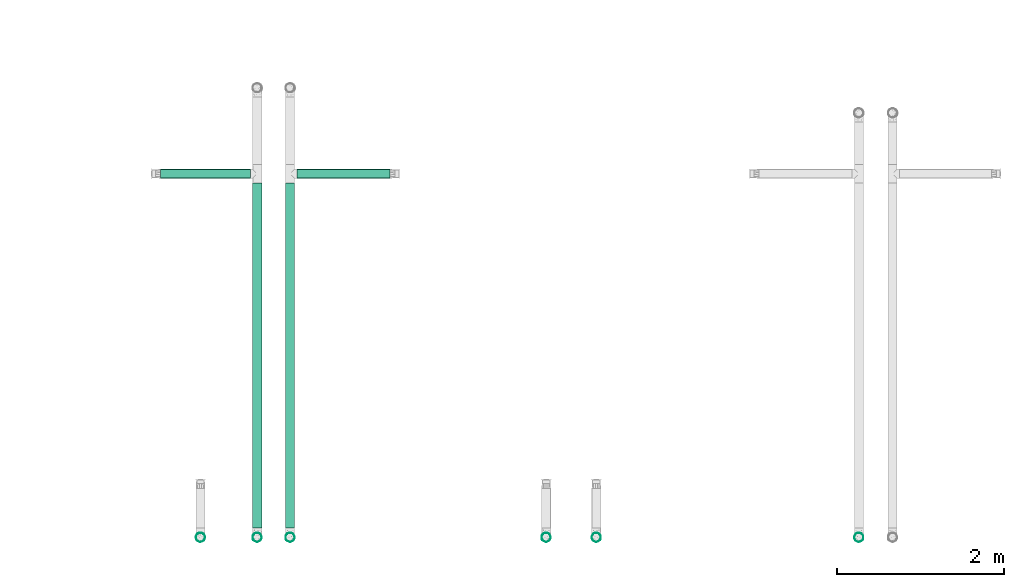
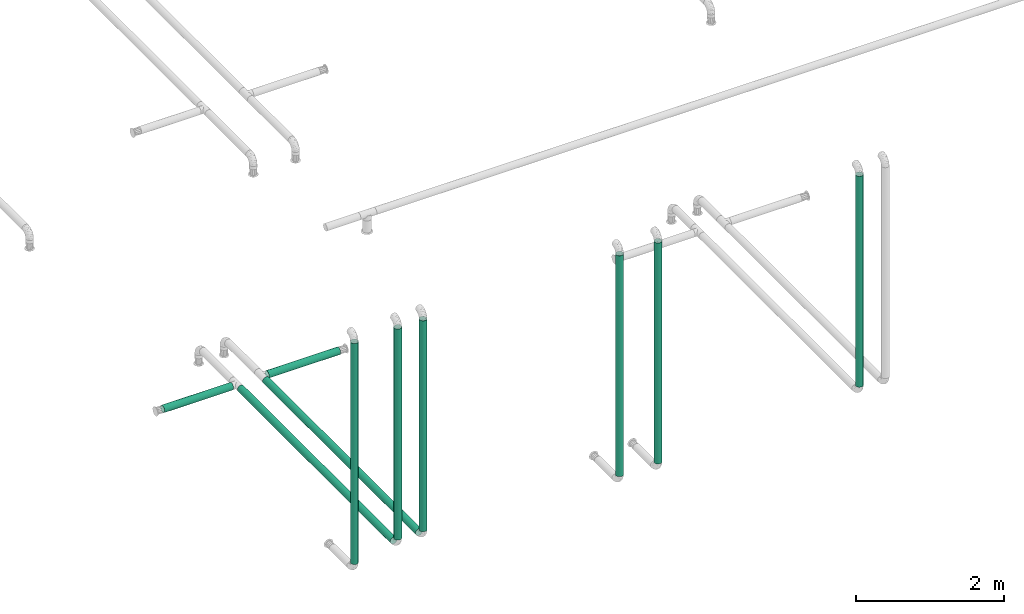
# One storey, part 1 of 115: 10 flow segments.
"""IFC2X3 building model written with IfcOpenShell, lengths in millimetres."""

from ifc_helpers import new_model, entity, si_unit, converted_unit, derived_unit, direction, frame, origin_with_axes, origin_2d_with_axis, place, context, subcontext, project, spatial, hollow_circle, extrude, source, transform, mapped, material, layer, layer_set, layer_usage, type_object, element, save


model = new_model("IFC2X3")

# Units and contexts
model_context = context("Model", 3, precision=1e-05, world=origin_with_axes(), true_north=direction((0.0, 1.0)))
body_context = subcontext(model_context, "Body", "Model", "MODEL_VIEW")
ifc_project = project(units=[si_unit("AREAUNIT", "SQUARE_METRE"), si_unit("VOLUMEUNIT", "CUBIC_METRE", prefix="DECI"), si_unit("TIMEUNIT", "SECOND"), si_unit("THERMODYNAMICTEMPERATUREUNIT", "DEGREE_CELSIUS"), si_unit("PRESSUREUNIT", "PASCAL"), si_unit("MASSUNIT", "GRAM", prefix="KILO"), si_unit("LENGTHUNIT", "METRE", prefix="MILLI"), si_unit("POWERUNIT", "WATT"), si_unit("ELECTRICCURRENTUNIT", "AMPERE"), si_unit("ELECTRICVOLTAGEUNIT", "VOLT"), derived_unit("VOLUMETRICFLOWRATEUNIT", [(si_unit("VOLUMEUNIT", "CUBIC_METRE", prefix="DECI"), 1), (si_unit("TIMEUNIT", "SECOND"), -1)]), derived_unit("LINEARVELOCITYUNIT", [(si_unit("LENGTHUNIT", "METRE"), 1), (si_unit("TIMEUNIT", "SECOND"), -1)]), derived_unit("MASSDENSITYUNIT", [(si_unit("MASSUNIT", "GRAM", prefix="KILO"), 1), (si_unit("VOLUMEUNIT", "CUBIC_METRE"), -1)]), converted_unit("PLANEANGLEUNIT", "DEGREE", entity("IfcRatioMeasure", 0.01745), si_unit("PLANEANGLEUNIT", "RADIAN"), dimensions=[0, 0, 0, 0, 0, 0, 0])], contexts=[model_context])

# Site, building, storey
site_placement = place(None, origin_with_axes())
site = spatial("IfcSite", under=ifc_project, at=site_placement, CompositionType="ELEMENT")
building_placement = place(site_placement, origin_with_axes())
building = spatial("IfcBuilding", under=site, at=building_placement, Name="mc-building", CompositionType="ELEMENT")
storey_placement = place(building_placement, frame((0.0, 0.0, 2950.0), z_axis=(0.0, 0.0, 1.0), x_axis=(1.0, 0.0, 0.0)))
storey = spatial("IfcBuildingStorey", under=building, at=storey_placement, Name="2. Korrus", CompositionType="ELEMENT", Elevation=2950.0)

# Flow segments
ifc_material = material(Name="FZ1")
ifc_layer = layer(ifc_material, 0.0)
ifc_layer_set = layer_set([ifc_layer], Name="FZ1")
ifc_layer_usage = layer_usage(ifc_layer_set, "AXIS1", "POSITIVE", 0.0)
duct_segment_type_1 = type_object("IfcDuctSegmentType", PredefinedType="RIGIDSEGMENT")
shared_shape_1 = source(origin_with_axes(), body_context, "Body", "SweptSolid", [
    extrude(hollow_circle(Radius=55.0, WallThickness=2.0, at=origin_2d_with_axis()), frame((0.0, 0.0, 0.0), z_axis=(1.0, 0.0, 0.0), x_axis=(0.0, 1.0, 0.0)), (0.0, 0.0, 1.0), 3480.0),
])
for number, where, z_axis, x_axis in (
    (1, (15796.4103, -687.64676, 2575.0), (1.0, 0.0, 0.0), (0.0, 0.0, 1.0)),
    (2, (8987.56202, -687.64676, 2575.0), (1.0, 0.0, 0.0), (0.0, 0.0, 1.0)),
    (3, (8592.78509, -687.64676, 2575.0), (1.0, 0.0, 0.0), (0.0, 0.0, 1.0)),
):
    element("IfcFlowSegment", number, at=place(storey_placement, frame(where, z_axis=z_axis, x_axis=x_axis)), inside=storey, type_object=duct_segment_type_1, material=ifc_layer_usage, context=body_context, shape_type="MappedRepresentation", body=[
        mapped(shared_shape_1, transform((0.0, 0.0, 0.0), scale=1.0)),
    ])
duct_segment_type_2 = type_object("IfcDuctSegmentType", Name="Safe", PredefinedType="RIGIDSEGMENT")
shared_shape_2 = source(origin_with_axes(), body_context, "Body", "SweptSolid", [
    extrude(hollow_circle(Radius=55.0, WallThickness=2.0, at=origin_2d_with_axis()), frame((0.0, 0.0, 0.0), z_axis=(1.0, 0.0, 0.0), x_axis=(0.0, 1.0, 0.0)), (0.0, 0.0, 1.0), 3645.0),
])
for number, where, z_axis, x_axis, name in (
    (4, (12653.05388, -687.64676, 2410.0), (1.0, 0.0, 0.0), (0.0, 0.0, 1.0), "Safe"),
    (5, (12053.05418, -687.64676, 2410.0), (1.0, 0.0, 0.0), (0.0, 0.0, 1.0), "Safe"),
    (6, (7914.47808, -687.64676, 2410.0), (1.0, 0.0, 0.0), (0.0, 0.0, 1.0), "Safe"),
):
    element("IfcFlowSegment", number, at=place(storey_placement, frame(where, z_axis=z_axis, x_axis=x_axis)), inside=storey, type_object=duct_segment_type_2, material=ifc_layer_usage, Name=name, context=body_context, shape_type="MappedRepresentation", body=[
        mapped(shared_shape_2, transform((0.0, 0.0, 0.0), scale=1.0)),
    ])
shared_shape_3 = source(origin_with_axes(), body_context, "Body", "SweptSolid", [
    extrude(hollow_circle(Radius=55.0, WallThickness=2.0, at=origin_2d_with_axis()), frame((0.0, 0.0, 0.0), z_axis=(1.0, 0.0, 0.0), x_axis=(0.0, 1.0, 0.0)), (0.0, 0.0, 1.0), 4133.9),
])
for number, where, z_axis, x_axis in (
    (7, (8987.56202, -577.64676, 2465.0), (0.0, 0.0, 1.0), (0.0, 1.0, 0.0)),
    (8, (8592.78509, -577.64676, 2465.0), (0.0, 0.0, 1.0), (0.0, 1.0, 0.0)),
):
    element("IfcFlowSegment", number, at=place(storey_placement, frame(where, z_axis=z_axis, x_axis=x_axis)), inside=storey, type_object=duct_segment_type_1, material=ifc_layer_usage, context=body_context, shape_type="MappedRepresentation", body=[
        mapped(shared_shape_3, transform((0.0, 0.0, 0.0), scale=1.0)),
    ])
shared_shape_4 = source(origin_with_axes(), body_context, "Body", "SweptSolid", [
    extrude(hollow_circle(Radius=55.0, WallThickness=2.0, at=origin_2d_with_axis()), frame((0.0, 0.0, 0.0), z_axis=(1.0, 0.0, 0.0), x_axis=(0.0, 1.0, 0.0)), (0.0, 0.0, 1.0), 1117.3),
])
flow_segment_1_placement = place(storey_placement, frame((9067.56202, 3666.26111, 2465.0), z_axis=(0.0, 0.0, 1.0), x_axis=(1.0, 0.0, 0.0)))
element("IfcFlowSegment", 9, at=flow_segment_1_placement, inside=storey, type_object=duct_segment_type_1, material=ifc_layer_usage, context=body_context, shape_type="MappedRepresentation", body=[
    mapped(shared_shape_4, transform((0.0, 0.0, 0.0), scale=1.0)),
])
shared_shape_5 = source(origin_with_axes(), body_context, "Body", "SweptSolid", [
    extrude(hollow_circle(Radius=55.0, WallThickness=2.0, at=origin_2d_with_axis()), frame((0.0, 0.0, 0.0), z_axis=(1.0, 0.0, 0.0), x_axis=(0.0, 1.0, 0.0)), (0.0, 0.0, 1.0), 1076.3),
])
flow_segment_2_placement = place(storey_placement, frame((8512.78509, 3666.26111, 2465.0), z_axis=(0.0, 0.0, 1.0), x_axis=(-1.0, 0.0, 0.0)))
element("IfcFlowSegment", 10, at=flow_segment_2_placement, inside=storey, type_object=duct_segment_type_1, material=ifc_layer_usage, context=body_context, shape_type="MappedRepresentation", body=[
    mapped(shared_shape_5, transform((0.0, 0.0, 0.0), scale=1.0)),
])

save(model, "model.ifc")
